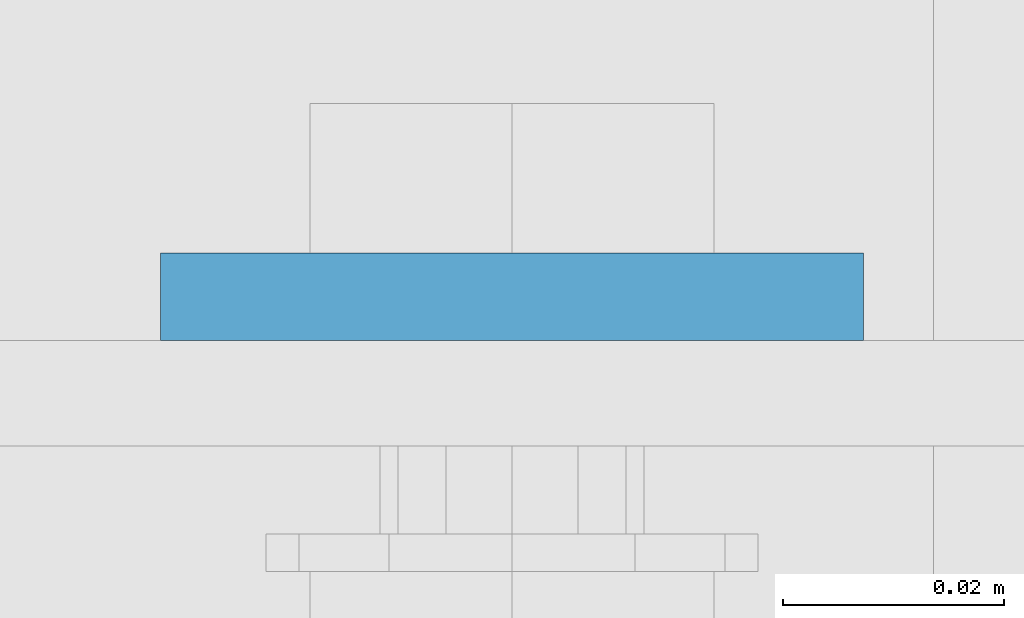
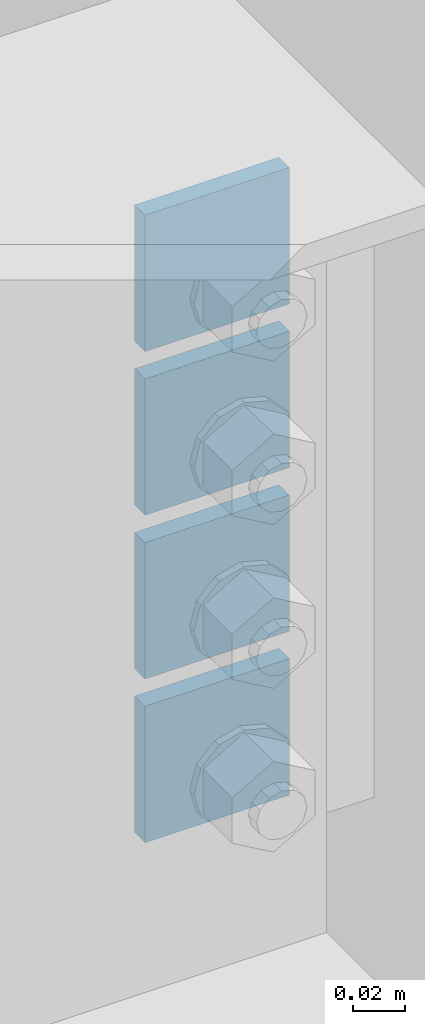
# One storey, part 938 of 975: 4 plates.
"""IFC2X3 building model written with IfcOpenShell, lengths in millimetres."""

import ifcopenshell
import ifcopenshell.guid

model = None  # the IFC model being written
_history = None  # IfcOwnerHistory: only IFC2X3 demands one
_inside = {}  # id of a spatial element -> (the spatial element, [elements in it])
_under = {}  # id of a project, library or spatial element -> (it, [spatial elements below it])
_declared = {}  # id of a project -> (the project, [libraries it declares])
_typed = {}  # id of a type object -> (the type object, [elements of that type])
_made_of = {}  # id of a material, layer set ... -> (it, [elements and type objects made of it])


def new_model(schema):
    """Start an empty IFC model of exactly this schema.

    Asked for "IFC4X3", IfcOpenShell would pick the latest addendum, in which some entities
    have other attributes; the version numbers below select the first issue.
    IFC2X3 requires an IfcOwnerHistory on every rooted entity: one is made here for all.
    """
    global model, _history
    if schema == "IFC4X3":
        model = ifcopenshell.file(schema_version=(4, 3, 0, 0))
    else:
        model = ifcopenshell.file(schema=schema)
    _inside.clear()
    _under.clear()
    _declared.clear()
    _typed.clear()
    _made_of.clear()
    _history = None
    if model.schema == "IFC2X3":
        org = make("IfcOrganization", Name="unknown")
        user = make(
            "IfcPersonAndOrganization",
            ThePerson=make("IfcPerson", FamilyName="unknown"),
            TheOrganization=org,
        )
        app = make(
            "IfcApplication",
            ApplicationDeveloper=org,
            Version="unknown",
            ApplicationFullName="unknown",
            ApplicationIdentifier="unknown",
        )
        _history = make(
            "IfcOwnerHistory",
            OwningUser=user,
            OwningApplication=app,
            ChangeAction="ADDED",
            CreationDate=0,
        )
    return model


def make(cls, **values):
    """One entity of the class cls with the attributes given. An attribute that is None is left unset."""
    return model.create_entity(
        cls, **{name: value for name, value in values.items() if value is not None}
    )


def rooted(cls, **values):
    """An entity with a GlobalId (a new one), such as an element, a storey or a relation."""
    return make(cls, GlobalId=ifcopenshell.guid.new(), OwnerHistory=_history, **values)


def si_unit(unit_type, name, prefix=None):
    """IfcSIUnit, for example si_unit("LENGTHUNIT", "METRE", prefix="MILLI")."""
    return make("IfcSIUnit", UnitType=unit_type, Prefix=prefix, Name=name)


def assignment(units):
    """IfcUnitAssignment: the units of a project."""
    return None if units is None else make("IfcUnitAssignment", Units=units)


def point(xyz):
    """IfcCartesianPoint."""
    return None if xyz is None else make("IfcCartesianPoint", Coordinates=xyz)


def direction(xyz):
    """IfcDirection."""
    return None if xyz is None else make("IfcDirection", DirectionRatios=xyz)


def frame(location, z_axis=None, x_axis=None):
    """IfcAxis2Placement3D, a coordinate frame: its origin and axes. An axis left out is left unset."""
    return make(
        "IfcAxis2Placement3D",
        Location=point(location),
        Axis=direction(z_axis),
        RefDirection=direction(x_axis),
    )


def origin_with_axes():
    """The frame at (0, 0, 0) with the z axis (0, 0, 1) and the x axis (1, 0, 0) written out."""
    return frame((0.0, 0.0, 0.0), z_axis=(0.0, 0.0, 1.0), x_axis=(1.0, 0.0, 0.0))


def place(relative_to, where):
    """IfcLocalPlacement: puts the frame where relative to a parent placement (None: the world)."""
    return make(
        "IfcLocalPlacement", PlacementRelTo=relative_to, RelativePlacement=where
    )


def context(
    kind, dimensions, precision=None, world=None, true_north=None, identifier=None
):
    """IfcGeometricRepresentationContext, for example the 3D "Model" context."""
    return make(
        "IfcGeometricRepresentationContext",
        ContextIdentifier=identifier,
        ContextType=kind,
        CoordinateSpaceDimension=dimensions,
        Precision=precision,
        WorldCoordinateSystem=world,
        TrueNorth=true_north,
    )


def subcontext(parent, identifier, kind, view, scale=None):
    """IfcGeometricRepresentationSubContext, for example "Body" below "Model"."""
    return make(
        "IfcGeometricRepresentationSubContext",
        ContextIdentifier=identifier,
        ContextType=kind,
        ParentContext=parent,
        TargetScale=scale,
        TargetView=view,
    )


def project(units=None, contexts=None):
    """IfcProject with its units and contexts."""
    return rooted(
        "IfcProject",
        Name="project",
        RepresentationContexts=contexts,
        UnitsInContext=assignment(units),
    )


def spatial(cls, under=None, at=None, **own):
    """A site, building, storey or space (cls), placed at a placement, below another one or the project."""
    s = rooted(cls, ObjectPlacement=at, **own)
    if under is not None:
        _under.setdefault(under.id(), (under, []))[1].append(s)
    return s


def faces_of(points, faces, orient=None, outer=None):
    """IfcFace entities. A face is a list of loops; a loop is a list of indices into points, from 0.

    orient and outer hold one flag for each loop. By default every Orientation is true, the
    first loop of a face is its IfcFaceOuterBound and the others are IfcFaceBound.
    """
    made = []
    for i, loops in enumerate(faces):
        bounds = []
        for j, loop in enumerate(loops):
            is_outer = j == 0 if outer is None else outer[i][j]
            bounds.append(
                make(
                    "IfcFaceOuterBound" if is_outer else "IfcFaceBound",
                    Bound=make("IfcPolyLoop", Polygon=[points[k] for k in loop]),
                    Orientation=True if orient is None else orient[i][j],
                )
            )
        made.append(make("IfcFace", Bounds=bounds))
    return made


def faceted_brep(points, faces, orient=None, outer=None, voids=None):
    """IfcFacetedBrep: a solid bounded by flat faces; with voids (closed shells), ...WithVoids."""
    shared = [point(p) for p in points]
    hull = make("IfcClosedShell", CfsFaces=faces_of(shared, faces, orient, outer))
    if voids is None:
        return make("IfcFacetedBrep", Outer=hull)
    return make(
        "IfcFacetedBrepWithVoids",
        Outer=hull,
        Voids=[
            make(cls, CfsFaces=faces_of(shared, fs, o, b)) for cls, fs, o, b in voids
        ],
    )


def shape(context_of_items, identifier, shape_type, items):
    """IfcShapeRepresentation: the items that make up one representation, for example the "Body"."""
    return make(
        "IfcShapeRepresentation",
        ContextOfItems=context_of_items,
        RepresentationIdentifier=identifier,
        RepresentationType=shape_type,
        Items=items,
    )


def material(Name=None, Category=None):
    """IfcMaterial."""
    return make("IfcMaterial", Name=Name, Category=Category)


def made_of(thing, what):
    """Note that an element or type object is made of a material, layer set ...; save() writes the relation."""
    if what is not None:
        _made_of.setdefault(what.id(), (what, []))[1].append(thing)
    return thing


def type_object(cls, material=None, **own):
    """A type object (cls), such as IfcWallType, which elements share."""
    return made_of(rooted(cls, **own), material)


def element(
    cls,
    number,
    at=None,
    inside=None,
    cuts=None,
    type_object=None,
    material=None,
    context=None,
    identifier="Body",
    shape_type=None,
    held_by="IfcProductDefinitionShape",
    body=None,
    shapes=None,
    **own,
):
    """One element of the class cls, such as IfcWall. Its Tag is "e" and its number.

    at: its placement. inside: the storey or other place that contains it. cuts: it is an
    opening in that element (IfcRelVoidsElement). A single representation is given by context,
    identifier, shape_type and body (its items); several are given by shapes. held_by: the class
    of the entity that holds the representations. save() writes the other relations.
    """
    e = rooted(cls, Tag="e%d" % number, ObjectPlacement=at, **own)
    if body is not None:
        shapes = [shape(context, identifier, shape_type, body)]
    if shapes is not None:
        e.Representation = make(held_by, Representations=shapes)
    if inside is not None:
        _inside.setdefault(inside.id(), (inside, []))[1].append(e)
    if cuts is not None:
        rooted(
            "IfcRelVoidsElement", RelatingBuildingElement=cuts, RelatedOpeningElement=e
        )
    if type_object is not None:
        _typed.setdefault(type_object.id(), (type_object, []))[1].append(e)
    return made_of(e, material)


def aggregate(whole, parts):
    """IfcRelAggregates: a whole, such as a stair, and the parts it consists of."""
    return rooted("IfcRelAggregates", RelatingObject=whole, RelatedObjects=parts)


def save(model, path):
    """Write the relations noted so far, then the file.

    IfcRelAggregates (storeys below a building ...), IfcRelContainedInSpatialStructure (elements
    in a storey), IfcRelDefinesByType, IfcRelAssociatesMaterial and IfcRelDeclares: one each for
    every whole, place, type object, material and project.
    """
    for whole, parts in _under.values():
        aggregate(whole, parts)
    for where, things in _inside.values():
        rooted(
            "IfcRelContainedInSpatialStructure",
            RelatedElements=things,
            RelatingStructure=where,
        )
    for kind, things in _typed.values():
        rooted("IfcRelDefinesByType", RelatedObjects=things, RelatingType=kind)
    for what, things in _made_of.values():
        rooted("IfcRelAssociatesMaterial", RelatedObjects=things, RelatingMaterial=what)
    for by, libraries in _declared.values():
        rooted("IfcRelDeclares", RelatingContext=by, RelatedDefinitions=libraries)
    model.write(path)


model = new_model("IFC2X3")

# Units and contexts
model_context = context("Model", 3, precision=1e-05, world=origin_with_axes())
body_context = subcontext(model_context, "Body", "Model", "MODEL_VIEW")
ifc_project = project(units=[si_unit("LENGTHUNIT", "METRE", prefix="MILLI"), si_unit("AREAUNIT", "SQUARE_METRE"), si_unit("VOLUMEUNIT", "CUBIC_METRE"), si_unit("MASSUNIT", "GRAM", prefix="KILO"), si_unit("TIMEUNIT", "SECOND"), si_unit("PLANEANGLEUNIT", "RADIAN"), si_unit("SOLIDANGLEUNIT", "STERADIAN"), si_unit("THERMODYNAMICTEMPERATUREUNIT", "DEGREE_CELSIUS"), si_unit("LUMINOUSINTENSITYUNIT", "LUMEN")], contexts=[model_context])

# Site, building, storey
site_placement = place(None, origin_with_axes())
site = spatial("IfcSite", under=ifc_project, at=site_placement, CompositionType="ELEMENT")
building_placement = place(site_placement, origin_with_axes())
building = spatial("IfcBuilding", under=site, at=building_placement, Name="Undefined", CompositionType="ELEMENT")
storey_placement = place(building_placement, origin_with_axes())
storey = spatial("IfcBuildingStorey", under=building, at=storey_placement, Name="Undefined", CompositionType="ELEMENT", Elevation=0.0)

# Plates
ifc_material = material(Name="STEEL/A36")
plate_type = type_object("IfcPlateType", PredefinedType="NOTDEFINED")
for number, where, z_axis, x_axis, name in (
    (1, (29622.749963295, 144.4625, 8185.15), (-0.999999999999998, 6.90000001668524e-08, 0.0), (0.0, 0.0, -1.0), "PLATE"),
    (2, (29622.749963295, 144.4625, 8261.35), (-0.999999999999998, 6.90000001668524e-08, 0.0), (0.0, 0.0, -1.0), "PLATE"),
    (3, (29622.749963295, 144.4625, 8337.55), (-0.999999999999998, 6.90000001668524e-08, 0.0), (0.0, 0.0, -1.0), "PLATE"),
    (4, (29622.749963295, 144.4625, 8413.75), (-0.999999999999998, 6.90000001668524e-08, 0.0), (0.0, 0.0, -1.0), "PLATE"),
):
    element("IfcPlate", number, at=place(storey_placement, frame(where, z_axis=z_axis, x_axis=x_axis)), inside=storey, type_object=plate_type, material=ifc_material, Name=name, context=body_context, shape_type="Brep", body=[
        faceted_brep([(0.0, -3.96900000000005, 0.0), (0.0, -3.96900000000005, 63.5), (0.0, 3.96900000000005, 63.5), (0.0, 3.96900000000005, 0.0), (63.5, -3.96900000000005, 63.5), (63.5, 3.96900000000005, 63.5), (63.5, -3.96900000000005, 0.0), (63.5, 3.96900000000005, 0.0)], [[[0, 1, 2, 3]], [[1, 4, 5, 2]], [[4, 6, 7, 5]], [[6, 0, 3, 7]], [[5, 7, 3, 2]], [[6, 4, 1, 0]]]),
    ])

save(model, "model.ifc")
